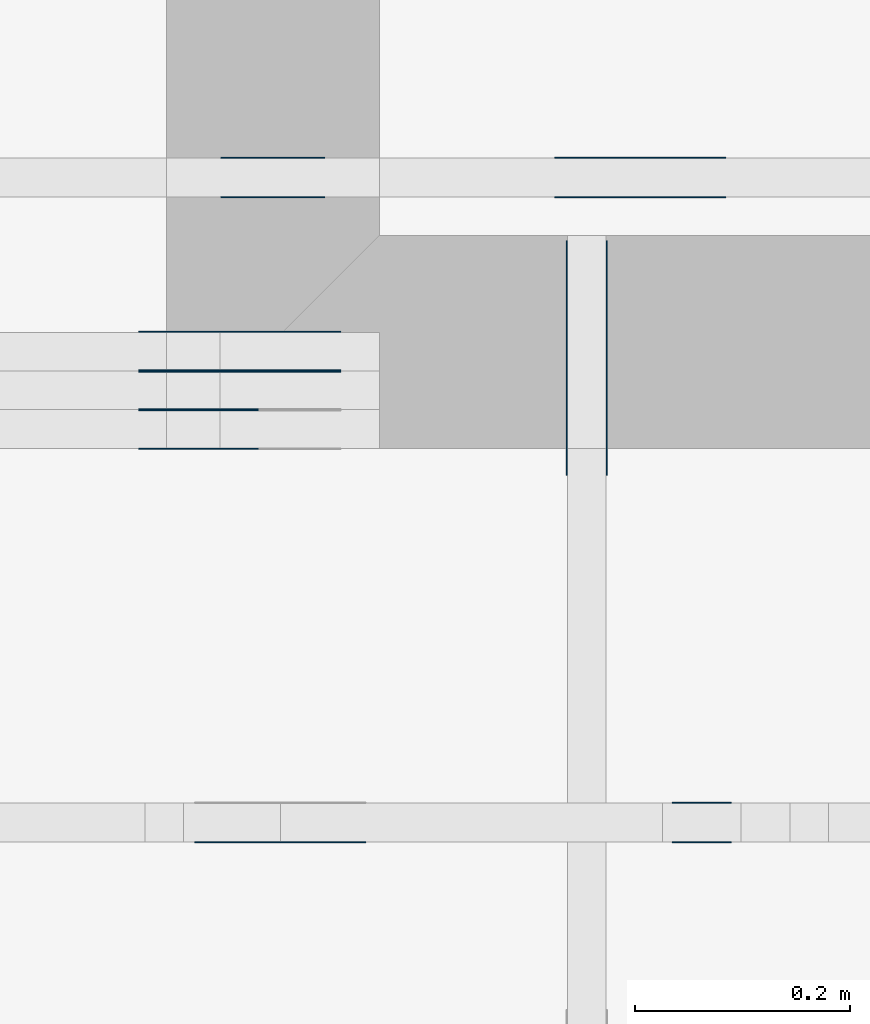
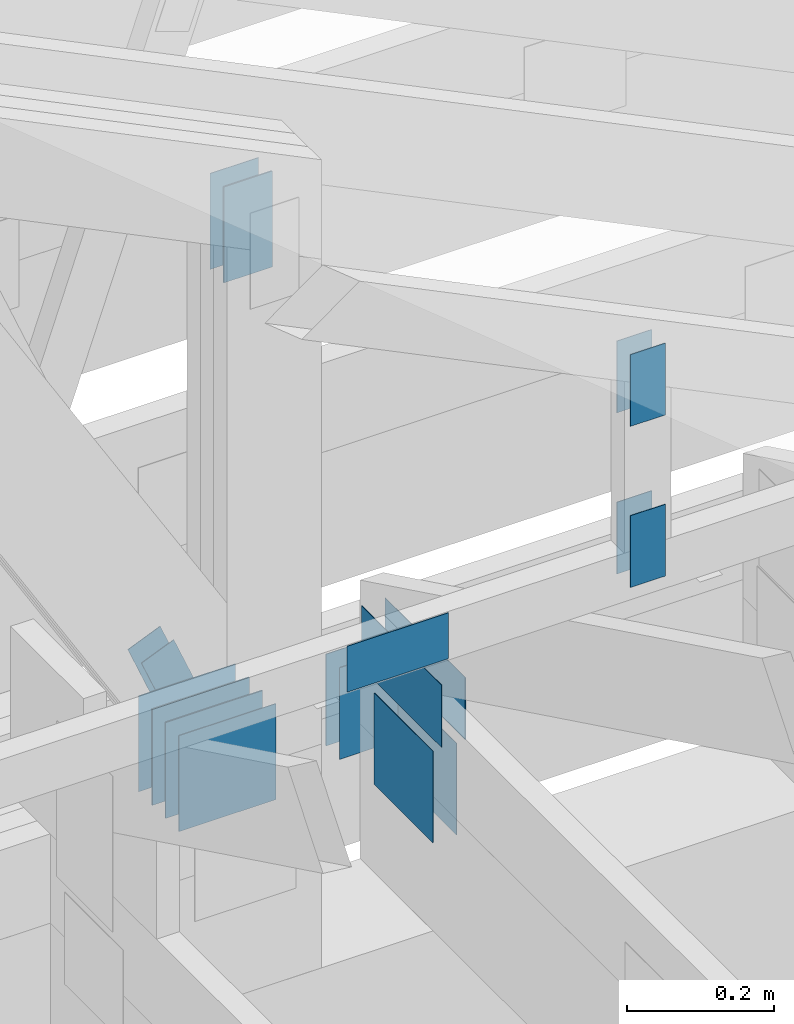
# One storey, part 129 of 159: 22 plates, 4 elements without a shape of their own.
"""IFC2X3 building model written with IfcOpenShell, lengths in millimetres."""

from ifc_helpers import new_model, si_unit, frame, origin, origin_with_axes, origin_2d, place, context, project, spatial, faceted_brep, element, aggregate, save


model = new_model("IFC2X3")

# Units and contexts
model_context = context("Model", 3, precision=1e-05, world=origin())
plan_context = context("Plan", 2, precision=1e-05, world=origin_2d())
ifc_project = project(units=[si_unit("LENGTHUNIT", "METRE", prefix="MILLI"), si_unit("AREAUNIT", "SQUARE_METRE"), si_unit("VOLUMEUNIT", "CUBIC_METRE"), si_unit("SOLIDANGLEUNIT", "STERADIAN"), si_unit("PLANEANGLEUNIT", "RADIAN"), si_unit("MASSUNIT", "GRAM"), si_unit("TIMEUNIT", "SECOND"), si_unit("THERMODYNAMICTEMPERATUREUNIT", "DEGREE_CELSIUS"), si_unit("LUMINOUSINTENSITYUNIT", "LUMEN")], contexts=[model_context, plan_context])

# Site, building, storey
site_placement = place(None, origin_with_axes())
site = spatial("IfcSite", under=ifc_project, at=site_placement, CompositionType="ELEMENT")
building_placement = place(site_placement, origin_with_axes())
building = spatial("IfcBuilding", under=site, at=building_placement, Name="Plan 1", CompositionType="ELEMENT")
storey_placement = place(building_placement, origin_with_axes())
storey = spatial("IfcBuildingStorey", under=building, at=storey_placement, Name="Etasje 1", CompositionType="ELEMENT", Elevation=0.0)

# Assembly, plates
assembly_1_placement = place(storey_placement, frame((10700.012663101485, 8801.999999990367, 0.0), z_axis=(0.0, -1.0, 6.123031769111886e-17), x_axis=(1.0, 0.0, 0.0)))
assembly_1 = element("IfcElementAssembly", 1, at=assembly_1_placement, inside=storey, Name="T8 (1)", AssemblyPlace="FACTORY", PredefinedType="TRUSS")
plate_1_placement = place(assembly_1_placement, frame((5888.0, 1290.2585957794156, -73.0), z_axis=(0.0, 0.0, 1.0), x_axis=(6.123031769111886e-17, -1.0, 0.0)))
plate_1 = element("IfcPlate", 2, at=plate_1_placement, Name="GNT100S 76x159", context=model_context, shape_type="Brep", body=[
    faceted_brep([(159.0000508575406, 76.0, 1.0), (5.085754060019099e-05, 76.0, 1.0), (5.085754060019099e-05, 0.0, 1.0), (159.0000508575406, 0.0, 1.0), (5.085754060019099e-05, 76.0, 6.22804673587734e-21), (159.0000508575406, 76.0, 1.9471247253822535e-14), (159.0000508575406, 0.0, 1.9471247253822535e-14), (5.085754060019099e-05, 0.0, 6.22804673587734e-21), (159.0, 3.4557877981217407e-10, 1.788345410772899e-30), (159.0, 3.4557884104249176e-10, 1.0), (1.1247455413666031e-32, 3.456080479040304e-10, 1.0), (0.0, 3.4560798667371273e-10, 0.0), (159.0, 76.00000000034561, 0.0), (159.0, 76.00000000034561, 1.0), (159.0, 3.4560798667371273e-10, 1.0), (159.0, 3.4560798667371273e-10, 0.0), (-2.4308653429145085e-63, 76.00000000034561, 0.0), (-3.7491518045553436e-33, 76.00000000034561, 1.0), (159.0, 76.0000000003456, 1.0), (159.0, 76.0000000003456, -7.888609052210118e-31), (4.232337364123881e-26, 3.4560798667371273e-10, -2.5914736138129785e-42), (6.123031773344224e-17, 3.4560798667371273e-10, 1.0), (9.36823860678351e-15, 76.00000000034561, 1.0), (9.307008289092391e-15, 76.00000000034561, -5.698710742950037e-31)], [[[0, 1, 2, 3]], [[4, 5, 6, 7]], [[8, 9, 10, 11]], [[12, 13, 14, 15]], [[16, 17, 18, 19]], [[20, 21, 22, 23]]]),
])
plate_2_placement = place(assembly_1_placement, frame((5888.0, 1290.2585957794156, -72.0), z_axis=(0.0, 0.0, 1.0), x_axis=(6.123031769111886e-17, -1.0, 0.0)))
plate_2 = element("IfcPlate", 3, at=plate_2_placement, Name="GNT100S 76x159", context=model_context, shape_type="Brep", body=[
    faceted_brep([(159.0000508575406, 76.0, 1.0), (5.085754060019099e-05, 76.0, 1.0), (5.085754060019099e-05, 0.0, 1.0), (159.0000508575406, 0.0, 1.0), (5.085754060019099e-05, 76.0, 6.22804673587734e-21), (159.0000508575406, 76.0, 1.9471247253822535e-14), (159.0000508575406, 0.0, 1.9471247253822535e-14), (5.085754060019099e-05, 0.0, 6.22804673587734e-21), (159.0, 3.4557877981217407e-10, 1.788345410772899e-30), (159.0, 3.4557884104249176e-10, 1.0), (1.1247455413666031e-32, 3.456080479040304e-10, 1.0), (0.0, 3.4560798667371273e-10, 0.0), (159.0, 76.00000000034561, 0.0), (159.0, 76.00000000034561, 1.0), (159.0, 3.4560798667371273e-10, 1.0), (159.0, 3.4560798667371273e-10, 0.0), (-2.4308653429145085e-63, 76.00000000034561, 0.0), (-3.7491518045553436e-33, 76.00000000034561, 1.0), (159.0, 76.0000000003456, 1.0), (159.0, 76.0000000003456, -7.888609052210118e-31), (4.232337364123881e-26, 3.4560798667371273e-10, -2.5914736138129785e-42), (6.123031773344224e-17, 3.4560798667371273e-10, 1.0), (9.36823860678351e-15, 76.00000000034561, 1.0), (9.307008289092391e-15, 76.00000000034561, -5.698710742950037e-31)], [[[0, 1, 2, 3]], [[4, 5, 6, 7]], [[8, 9, 10, 11]], [[12, 13, 14, 15]], [[16, 17, 18, 19]], [[20, 21, 22, 23]]]),
])
plate_3_placement = place(assembly_1_placement, frame((5888.0, 1290.2585957794156, -109.0), z_axis=(0.0, 0.0, 1.0), x_axis=(6.123031769111886e-17, -1.0, 0.0)))
plate_3 = element("IfcPlate", 4, at=plate_3_placement, Name="GNT100S 76x159", context=model_context, shape_type="Brep", body=[
    faceted_brep([(159.0000508575406, 76.0, 1.0), (5.085754060019099e-05, 76.0, 1.0), (5.085754060019099e-05, 0.0, 1.0), (159.0000508575406, 0.0, 1.0), (5.085754060019099e-05, 76.0, 6.22804673587734e-21), (159.0000508575406, 76.0, 1.9471247253822535e-14), (159.0000508575406, 0.0, 1.9471247253822535e-14), (5.085754060019099e-05, 0.0, 6.22804673587734e-21), (159.0, 3.4557877981217407e-10, 1.788345410772899e-30), (159.0, 3.4557884104249176e-10, 1.0), (1.1247455413666031e-32, 3.456080479040304e-10, 1.0), (0.0, 3.4560798667371273e-10, 0.0), (159.0, 76.00000000034561, 0.0), (159.0, 76.00000000034561, 1.0), (159.0, 3.4560798667371273e-10, 1.0), (159.0, 3.4560798667371273e-10, 0.0), (-2.4308653429145085e-63, 76.00000000034561, 0.0), (-3.7491518045553436e-33, 76.00000000034561, 1.0), (159.0, 76.0000000003456, 1.0), (159.0, 76.0000000003456, -7.888609052210118e-31), (4.232337364123881e-26, 3.4560798667371273e-10, -2.5914736138129785e-42), (6.123031773344224e-17, 3.4560798667371273e-10, 1.0), (9.36823860678351e-15, 76.00000000034561, 1.0), (9.307008289092391e-15, 76.00000000034561, -5.698710742950037e-31)], [[[0, 1, 2, 3]], [[4, 5, 6, 7]], [[8, 9, 10, 11]], [[12, 13, 14, 15]], [[16, 17, 18, 19]], [[20, 21, 22, 23]]]),
])
plate_4_placement = place(assembly_1_placement, frame((5928.0, 304.75, 0.0), z_axis=(0.0, 0.0, 1.0), x_axis=(6.123031769111886e-17, 1.0, 0.0)))
plate_4 = element("IfcPlate", 5, at=plate_4_placement, Name="GNT100S 152x159", context=model_context, shape_type="Brep", body=[
    faceted_brep([(159.0, 152.0, 1.0), (0.0, 152.0, 1.0), (0.0, 0.0, 1.0), (159.0, 0.0, 1.0), (0.0, 152.0, 0.0), (159.0, 152.0, 1.9471241025775798e-14), (159.0, 0.0, 1.9471241025775798e-14), (0.0, 0.0, 0.0), (159.0, -2.92068615386637e-14, 1.788345410772899e-30), (159.0, -2.914563122097258e-14, 1.0), (1.1247455413666031e-32, 6.123031769111886e-17, 1.0), (0.0, 0.0, 0.0), (159.0, 152.0, 0.0), (159.0, 152.0, 1.0), (159.0, 0.0, 1.0), (159.0, 0.0, 0.0), (0.0, 152.0, 0.0), (-3.7491518045553436e-33, 152.0, 1.0), (159.0, 152.0, 1.0), (159.0, 152.0, 0.0), (0.0, 0.0, 0.0), (6.123031769111886e-17, -7.498303609110687e-33, 1.0), (1.8675246895791253e-14, 152.0, 1.0), (1.8614016578100134e-14, 152.0, -1.1397421485848245e-30)], [[[0, 1, 2, 3]], [[4, 5, 6, 7]], [[8, 9, 10, 11]], [[12, 13, 14, 15]], [[16, 17, 18, 19]], [[20, 21, 22, 23]]]),
])
plate_5_placement = place(assembly_1_placement, frame((5928.0, 304.75, -37.0), z_axis=(0.0, 0.0, 1.0), x_axis=(6.123031769111886e-17, 1.0, 0.0)))
plate_5 = element("IfcPlate", 6, at=plate_5_placement, Name="GNT100S 152x159", context=model_context, shape_type="Brep", body=[
    faceted_brep([(159.0, 152.0, 1.0), (0.0, 152.0, 1.0), (0.0, 0.0, 1.0), (159.0, 0.0, 1.0), (0.0, 152.0, 0.0), (159.0, 152.0, 1.9471241025775798e-14), (159.0, 0.0, 1.9471241025775798e-14), (0.0, 0.0, 0.0), (159.0, -2.92068615386637e-14, 1.788345410772899e-30), (159.0, -2.914563122097258e-14, 1.0), (1.1247455413666031e-32, 6.123031769111886e-17, 1.0), (0.0, 0.0, 0.0), (159.0, 152.0, 0.0), (159.0, 152.0, 1.0), (159.0, 0.0, 1.0), (159.0, 0.0, 0.0), (0.0, 152.0, 0.0), (-3.7491518045553436e-33, 152.0, 1.0), (159.0, 152.0, 1.0), (159.0, 152.0, 0.0), (0.0, 0.0, 0.0), (6.123031769111886e-17, -7.498303609110687e-33, 1.0), (1.8675246895791253e-14, 152.0, 1.0), (1.8614016578100134e-14, 152.0, -1.1397421485848245e-30)], [[[0, 1, 2, 3]], [[4, 5, 6, 7]], [[8, 9, 10, 11]], [[12, 13, 14, 15]], [[16, 17, 18, 19]], [[20, 21, 22, 23]]]),
])
plate_6_placement = place(assembly_1_placement, frame((5928.0, 304.75, -36.0), z_axis=(0.0, 0.0, 1.0), x_axis=(6.123031769111886e-17, 1.0, 0.0)))
plate_6 = element("IfcPlate", 7, at=plate_6_placement, Name="GNT100S 152x159", context=model_context, shape_type="Brep", body=[
    faceted_brep([(159.0, 152.0, 1.0), (0.0, 152.0, 1.0), (0.0, 0.0, 1.0), (159.0, 0.0, 1.0), (0.0, 152.0, 0.0), (159.0, 152.0, 1.9471241025775798e-14), (159.0, 0.0, 1.9471241025775798e-14), (0.0, 0.0, 0.0), (159.0, -2.92068615386637e-14, 1.788345410772899e-30), (159.0, -2.914563122097258e-14, 1.0), (1.1247455413666031e-32, 6.123031769111886e-17, 1.0), (0.0, 0.0, 0.0), (159.0, 152.0, 0.0), (159.0, 152.0, 1.0), (159.0, 0.0, 1.0), (159.0, 0.0, 0.0), (0.0, 152.0, 0.0), (-3.7491518045553436e-33, 152.0, 1.0), (159.0, 152.0, 1.0), (159.0, 152.0, 0.0), (0.0, 0.0, 0.0), (6.123031769111886e-17, -7.498303609110687e-33, 1.0), (1.8675246895791253e-14, 152.0, 1.0), (1.8614016578100134e-14, 152.0, -1.1397421485848245e-30)], [[[0, 1, 2, 3]], [[4, 5, 6, 7]], [[8, 9, 10, 11]], [[12, 13, 14, 15]], [[16, 17, 18, 19]], [[20, 21, 22, 23]]]),
])
plate_7_placement = place(assembly_1_placement, frame((5928.0, 304.75, -73.0), z_axis=(0.0, 0.0, 1.0), x_axis=(6.123031769111886e-17, 1.0, 0.0)))
plate_7 = element("IfcPlate", 8, at=plate_7_placement, Name="GNT100S 152x159", context=model_context, shape_type="Brep", body=[
    faceted_brep([(159.0, 152.0, 1.0), (0.0, 152.0, 1.0), (0.0, 0.0, 1.0), (159.0, 0.0, 1.0), (0.0, 152.0, 0.0), (159.0, 152.0, 1.9471241025775798e-14), (159.0, 0.0, 1.9471241025775798e-14), (0.0, 0.0, 0.0), (159.0, -2.92068615386637e-14, 1.788345410772899e-30), (159.0, -2.914563122097258e-14, 1.0), (1.1247455413666031e-32, 6.123031769111886e-17, 1.0), (0.0, 0.0, 0.0), (159.0, 152.0, 0.0), (159.0, 152.0, 1.0), (159.0, 0.0, 1.0), (159.0, 0.0, 0.0), (0.0, 152.0, 0.0), (-3.7491518045553436e-33, 152.0, 1.0), (159.0, 152.0, 1.0), (159.0, 152.0, 0.0), (0.0, 0.0, 0.0), (6.123031769111886e-17, -7.498303609110687e-33, 1.0), (1.8675246895791253e-14, 152.0, 1.0), (1.8614016578100134e-14, 152.0, -1.1397421485848245e-30)], [[[0, 1, 2, 3]], [[4, 5, 6, 7]], [[8, 9, 10, 11]], [[12, 13, 14, 15]], [[16, 17, 18, 19]], [[20, 21, 22, 23]]]),
])
plate_8_placement = place(assembly_1_placement, frame((5928.0, 304.75, -72.0), z_axis=(0.0, 0.0, 1.0), x_axis=(6.123031769111886e-17, 1.0, 0.0)))
plate_8 = element("IfcPlate", 9, at=plate_8_placement, Name="GNT100S 152x159", context=model_context, shape_type="Brep", body=[
    faceted_brep([(159.0, 152.0, 1.0), (0.0, 152.0, 1.0), (0.0, 0.0, 1.0), (159.0, 0.0, 1.0), (0.0, 152.0, 0.0), (159.0, 152.0, 1.9471241025775798e-14), (159.0, 0.0, 1.9471241025775798e-14), (0.0, 0.0, 0.0), (159.0, -2.92068615386637e-14, 1.788345410772899e-30), (159.0, -2.914563122097258e-14, 1.0), (1.1247455413666031e-32, 6.123031769111886e-17, 1.0), (0.0, 0.0, 0.0), (159.0, 152.0, 0.0), (159.0, 152.0, 1.0), (159.0, 0.0, 1.0), (159.0, 0.0, 0.0), (0.0, 152.0, 0.0), (-3.7491518045553436e-33, 152.0, 1.0), (159.0, 152.0, 1.0), (159.0, 152.0, 0.0), (0.0, 0.0, 0.0), (6.123031769111886e-17, -7.498303609110687e-33, 1.0), (1.8675246895791253e-14, 152.0, 1.0), (1.8614016578100134e-14, 152.0, -1.1397421485848245e-30)], [[[0, 1, 2, 3]], [[4, 5, 6, 7]], [[8, 9, 10, 11]], [[12, 13, 14, 15]], [[16, 17, 18, 19]], [[20, 21, 22, 23]]]),
])
plate_9_placement = place(assembly_1_placement, frame((5928.0, 304.75, -109.0), z_axis=(0.0, 0.0, 1.0), x_axis=(6.123031769111886e-17, 1.0, 0.0)))
plate_9 = element("IfcPlate", 10, at=plate_9_placement, Name="GNT100S 152x159", context=model_context, shape_type="Brep", body=[
    faceted_brep([(159.0, 152.0, 1.0), (0.0, 152.0, 1.0), (0.0, 0.0, 1.0), (159.0, 0.0, 1.0), (0.0, 152.0, 0.0), (159.0, 152.0, 1.9471241025775798e-14), (159.0, 0.0, 1.9471241025775798e-14), (0.0, 0.0, 0.0), (159.0, -2.92068615386637e-14, 1.788345410772899e-30), (159.0, -2.914563122097258e-14, 1.0), (1.1247455413666031e-32, 6.123031769111886e-17, 1.0), (0.0, 0.0, 0.0), (159.0, 152.0, 0.0), (159.0, 152.0, 1.0), (159.0, 0.0, 1.0), (159.0, 0.0, 0.0), (0.0, 152.0, 0.0), (-3.7491518045553436e-33, 152.0, 1.0), (159.0, 152.0, 1.0), (159.0, 152.0, 0.0), (0.0, 0.0, 0.0), (6.123031769111886e-17, -7.498303609110687e-33, 1.0), (1.8675246895791253e-14, 152.0, 1.0), (1.8614016578100134e-14, 152.0, -1.1397421485848245e-30)], [[[0, 1, 2, 3]], [[4, 5, 6, 7]], [[8, 9, 10, 11]], [[12, 13, 14, 15]], [[16, 17, 18, 19]], [[20, 21, 22, 23]]]),
])
aggregate(assembly_1, [plate_1, plate_2, plate_3, plate_4, plate_5, plate_6, plate_7, plate_8, plate_9])

assembly_2_placement = place(storey_placement, frame((10000.012663278096, 9072.000080051337, 1.1021457184401395e-15), z_axis=(9.811600543477555e-09, 1.0, 6.123031769111886e-17), x_axis=(-1.0, 9.811600543477555e-09, 0.0)))
assembly_2 = element("IfcElementAssembly", 11, at=assembly_2_placement, inside=storey, Name="T9 (79)", AssemblyPlace="FACTORY", PredefinedType="TRUSS")
plate_10_placement = place(assembly_2_placement, frame((-7022.14892578125, 147.0, 0.0), z_axis=(0.0, 0.0, 1.0), x_axis=(1.0, 0.0, 0.0)))
plate_10 = element("IfcPlate", 12, at=plate_10_placement, Name="GNT100S 152x159", context=model_context, shape_type="Brep", body=[
    faceted_brep([(159.0, 152.0, 1.0), (0.0, 152.0, 1.0), (0.0, 0.0, 1.0), (159.0, 0.0, 1.0), (0.0, 152.0, 0.0), (159.0, 152.0, 1.9471241025775798e-14), (159.0, 0.0, 1.9471241025775798e-14), (0.0, 0.0, 0.0), (159.00020807865712, -2.920689976083054e-14, 1.7883477511283173e-30), (159.00020807865712, -2.914566944313942e-14, 1.0), (0.00020807865712413331, 6.119209552427751e-17, 1.0), (0.00020807865712413331, -3.822216684135623e-20, 2.340355418539191e-36), (159.00020807865712, 152.0, 0.0), (159.00020807865712, 152.0, 1.0), (159.00020807865712, 0.0, 1.0), (159.00020807865712, 0.0, 0.0), (0.00020807865712413331, 152.0, 0.0), (0.00020807865712413331, 152.0, 1.0), (159.00020807865712, 152.0, 1.0), (159.00020807865712, 152.0, 0.0), (0.00020807865712413331, 0.0, 0.0), (0.00020807865712419455, -7.498303609110687e-33, 1.0), (0.00020807865714280856, 152.0, 1.0), (0.00020807865714274733, 152.0, -1.1397427715968304e-30)], [[[0, 1, 2, 3]], [[4, 5, 6, 7]], [[8, 9, 10, 11]], [[12, 13, 14, 15]], [[16, 17, 18, 19]], [[20, 21, 22, 23]]]),
])
plate_11_placement = place(assembly_2_placement, frame((-7022.14892578125, 147.0, -37.0), z_axis=(0.0, 0.0, 1.0), x_axis=(1.0, 0.0, 0.0)))
plate_11 = element("IfcPlate", 13, at=plate_11_placement, Name="GNT100S 152x159", context=model_context, shape_type="Brep", body=[
    faceted_brep([(159.0, 152.0, 1.0), (0.0, 152.0, 1.0), (0.0, 0.0, 1.0), (159.0, 0.0, 1.0), (0.0, 152.0, 0.0), (159.0, 152.0, 1.9471241025775798e-14), (159.0, 0.0, 1.9471241025775798e-14), (0.0, 0.0, 0.0), (159.00020807865712, -2.920689976083054e-14, 1.7883477511283173e-30), (159.00020807865712, -2.914566944313942e-14, 1.0), (0.00020807865712413331, 6.119209552427751e-17, 1.0), (0.00020807865712413331, -3.822216684135623e-20, 2.340355418539191e-36), (159.00020807865712, 152.0, 0.0), (159.00020807865712, 152.0, 1.0), (159.00020807865712, 0.0, 1.0), (159.00020807865712, 0.0, 0.0), (0.00020807865712413331, 152.0, 0.0), (0.00020807865712413331, 152.0, 1.0), (159.00020807865712, 152.0, 1.0), (159.00020807865712, 152.0, 0.0), (0.00020807865712413331, 0.0, 0.0), (0.00020807865712419455, -7.498303609110687e-33, 1.0), (0.00020807865714280856, 152.0, 1.0), (0.00020807865714274733, 152.0, -1.1397427715968304e-30)], [[[0, 1, 2, 3]], [[4, 5, 6, 7]], [[8, 9, 10, 11]], [[12, 13, 14, 15]], [[16, 17, 18, 19]], [[20, 21, 22, 23]]]),
])
plate_12_placement = place(assembly_2_placement, frame((-6598.611314110998, 305.4957525768082, 0.0), z_axis=(0.0, 0.0, 1.0), x_axis=(0.3861849324176126, 0.9224213776651125, 0.0)))
plate_12 = element("IfcPlate", 14, at=plate_12_placement, Name="GNT100S 55x119", context=model_context, shape_type="Brep", body=[
    faceted_brep([(119.00000321189373, 55.00025658546747, 1.0), (0.0, 55.00025658546747, 1.0), (8.409291740463232e-05, 5.03993305756012e-05, 1.0), (119.00008730481068, 5.03993305756012e-05, 1.0), (0.0, 55.00025658546747, 0.0), (119.00000321189373, 55.00025658546747, 1.4572816003816836e-14), (119.00008730481068, 0.0, 1.4572826301888877e-14), (8.409291740463232e-05, 0.0, 1.0298072096517311e-20), (119.00004365240966, 0.00012829272412097185, 3.894471088794039e-30), (119.00004365240966, 0.00012829272412103308, 1.0), (4.36524101132818e-05, 0.0001282927250941314, 1.0), (4.36524101132818e-05, 0.00012829272509407017, 3.009265538105056e-36), (119.00004365240966, 55.000128292724185, 0.0), (119.00004365240966, 55.000128292724185, 1.0), (119.00004365240966, 0.0001282927241845755, 1.0), (119.00004365240966, 0.0001282927241845755, 0.0), (4.365240965853445e-05, 55.000128292724185, 0.0), (4.365240965853445e-05, 55.000128292724185, 1.0), (119.00004365240966, 55.00012829272418, 1.0), (119.00004365240966, 55.00012829272418, -3.944304526105059e-31), (4.365241011328186e-05, 0.00012829272509407017, -3.385423730368188e-36), (4.365241011334309e-05, 0.00012829272509407017, 1.0), (4.3652409680430105e-05, 55.000128292724185, 1.0), (4.3652409680368875e-05, 55.000128292724185, -1.3369286575630868e-30)], [[[0, 1, 2, 3]], [[4, 5, 6, 7]], [[8, 9, 10, 11]], [[12, 13, 14, 15]], [[16, 17, 18, 19]], [[20, 21, 22, 23]]]),
])
plate_13_placement = place(assembly_2_placement, frame((-6598.611314110998, 305.4957525768082, -37.0), z_axis=(0.0, 0.0, 1.0), x_axis=(0.3861849324176126, 0.9224213776651125, 0.0)))
plate_13 = element("IfcPlate", 15, at=plate_13_placement, Name="GNT100S 55x119", context=model_context, shape_type="Brep", body=[
    faceted_brep([(119.00000321189373, 55.00025658546747, 1.0), (0.0, 55.00025658546747, 1.0), (8.409291740463232e-05, 5.03993305756012e-05, 1.0), (119.00008730481068, 5.03993305756012e-05, 1.0), (0.0, 55.00025658546747, 0.0), (119.00000321189373, 55.00025658546747, 1.4572816003816836e-14), (119.00008730481068, 0.0, 1.4572826301888877e-14), (8.409291740463232e-05, 0.0, 1.0298072096517311e-20), (119.00004365240966, 0.00012829272412097185, 3.894471088794039e-30), (119.00004365240966, 0.00012829272412103308, 1.0), (4.36524101132818e-05, 0.0001282927250941314, 1.0), (4.36524101132818e-05, 0.00012829272509407017, 3.009265538105056e-36), (119.00004365240966, 55.000128292724185, 0.0), (119.00004365240966, 55.000128292724185, 1.0), (119.00004365240966, 0.0001282927241845755, 1.0), (119.00004365240966, 0.0001282927241845755, 0.0), (4.365240965853445e-05, 55.000128292724185, 0.0), (4.365240965853445e-05, 55.000128292724185, 1.0), (119.00004365240966, 55.00012829272418, 1.0), (119.00004365240966, 55.00012829272418, -3.944304526105059e-31), (4.365241011328186e-05, 0.00012829272509407017, -3.385423730368188e-36), (4.365241011334309e-05, 0.00012829272509407017, 1.0), (4.3652409680430105e-05, 55.000128292724185, 1.0), (4.3652409680368875e-05, 55.000128292724185, -1.3369286575630868e-30)], [[[0, 1, 2, 3]], [[4, 5, 6, 7]], [[8, 9, 10, 11]], [[12, 13, 14, 15]], [[16, 17, 18, 19]], [[20, 21, 22, 23]]]),
])
aggregate(assembly_2, [plate_10, plate_11, plate_12, plate_13])

assembly_3_placement = place(storey_placement, frame((16875.02226140475, -699.9989301294827, 1.1021457184401395e-15), z_axis=(-1.0, 1.836909530733566e-16, 6.123031769111886e-17), x_axis=(-1.836909530733566e-16, -1.0, 0.0)))
assembly_3 = element("IfcElementAssembly", 16, at=assembly_3_placement, inside=storey, Name="V7 (32)", AssemblyPlace="FACTORY", PredefinedType="TRUSS")
plate_14_placement = place(assembly_3_placement, frame((-9694.9990234375, 319.5, 0.0), z_axis=(0.0, 0.0, 1.0), x_axis=(1.0, 0.0, 0.0)))
plate_14 = element("IfcPlate", 17, at=plate_14_placement, Name="GNT100S 103x218", context=model_context, shape_type="Brep", body=[
    faceted_brep([(218.0, 103.0, 1.0), (0.0, 103.0, 1.0), (0.0, 0.0, 1.0), (218.0, 0.0, 1.0), (0.0, 103.0, 0.0), (218.0, 103.0, 2.6696418513327824e-14), (218.0, 0.0, 2.6696418513327824e-14), (0.0, 0.0, 0.0), (218.00009946359205, -4.004464604055376e-14, 2.4519463988915115e-30), (218.00009946359205, -3.998341572286264e-14, 1.0), (9.946359205059707e-05, 6.121204712909899e-17, 1.0), (9.946359205059707e-05, -1.827056201987371e-20, 1.1187123168721576e-36), (218.00009946359205, 103.0, 0.0), (218.00009946359205, 103.0, 1.0), (218.00009946359205, 0.0, 1.0), (218.00009946359205, 0.0, 0.0), (9.946359205059707e-05, 103.0, 0.0), (9.946359205059707e-05, 103.0, 1.0), (218.00009946359205, 102.99999999999999, 1.0), (218.00009946359205, 102.99999999999999, -7.888609052210118e-31), (9.946359205059707e-05, 0.0, 0.0), (9.94635920506583e-05, -7.498303609110687e-33, 1.0), (9.946359206327175e-05, 103.0, 1.0), (9.946359206321052e-05, 103.0, -7.723249910891245e-31)], [[[0, 1, 2, 3]], [[4, 5, 6, 7]], [[8, 9, 10, 11]], [[12, 13, 14, 15]], [[16, 17, 18, 19]], [[20, 21, 22, 23]]]),
])
plate_15_placement = place(assembly_3_placement, frame((-9694.9990234375, 319.5, -37.0), z_axis=(0.0, 0.0, 1.0), x_axis=(1.0, 0.0, 0.0)))
plate_15 = element("IfcPlate", 18, at=plate_15_placement, Name="GNT100S 103x218", context=model_context, shape_type="Brep", body=[
    faceted_brep([(218.0, 103.0, 1.0), (0.0, 103.0, 1.0), (0.0, 0.0, 1.0), (218.0, 0.0, 1.0), (0.0, 103.0, 0.0), (218.0, 103.0, 2.6696418513327824e-14), (218.0, 0.0, 2.6696418513327824e-14), (0.0, 0.0, 0.0), (218.00009946359205, -4.004464604055376e-14, 2.4519463988915115e-30), (218.00009946359205, -3.998341572286264e-14, 1.0), (9.946359205059707e-05, 6.121204712909899e-17, 1.0), (9.946359205059707e-05, -1.827056201987371e-20, 1.1187123168721576e-36), (218.00009946359205, 103.0, 0.0), (218.00009946359205, 103.0, 1.0), (218.00009946359205, 0.0, 1.0), (218.00009946359205, 0.0, 0.0), (9.946359205059707e-05, 103.0, 0.0), (9.946359205059707e-05, 103.0, 1.0), (218.00009946359205, 102.99999999999999, 1.0), (218.00009946359205, 102.99999999999999, -7.888609052210118e-31), (9.946359205059707e-05, 0.0, 0.0), (9.94635920506583e-05, -7.498303609110687e-33, 1.0), (9.946359206327175e-05, 103.0, 1.0), (9.946359206321052e-05, 103.0, -7.723249910891245e-31)], [[[0, 1, 2, 3]], [[4, 5, 6, 7]], [[8, 9, 10, 11]], [[12, 13, 14, 15]], [[16, 17, 18, 19]], [[20, 21, 22, 23]]]),
])
plate_16_placement = place(assembly_3_placement, frame((-9659.9990234375, 147.0, 0.0), z_axis=(0.0, 0.0, 1.0), x_axis=(1.0, 0.0, 0.0)))
plate_16 = element("IfcPlate", 19, at=plate_16_placement, Name="GNT100S 152x159", context=model_context, shape_type="Brep", body=[
    faceted_brep([(159.0, 152.0, 1.0), (0.0, 152.0, 1.0), (0.0, 0.0, 1.0), (159.0, 0.0, 1.0), (0.0, 152.0, 0.0), (159.0, 152.0, 1.9471241025775798e-14), (159.0, 0.0, 1.9471241025775798e-14), (0.0, 0.0, 0.0), (159.00009946362115, 1.69745086203597e-13, 1.788346529485543e-30), (159.00009946362115, 1.6980631652128811e-13, 1.0), (9.946362115442753e-05, 1.990131780599518e-13, 1.0), (9.946362115442753e-05, 1.989519477422607e-13, 1.1187126440350437e-36), (159.00009946362115, 152.00000000000023, 0.0), (159.00009946362115, 152.00000000000023, 1.0), (159.00009946362115, 1.9895196601282805e-13, 1.0), (159.00009946362115, 1.9895196601282805e-13, 0.0), (9.946362115442753e-05, 152.00000000000023, 0.0), (9.946362115442753e-05, 152.00000000000023, 1.0), (159.00009946362115, 152.00000000000023, 1.0), (159.00009946362115, 152.00000000000023, 0.0), (9.946362115442753e-05, 1.9895196601282805e-13, 0.0), (9.946362115448876e-05, 1.9895196601282805e-13, 1.0), (9.946362117310278e-05, 152.00000000000023, 1.0), (9.946362117304154e-05, 152.00000000000023, -1.1397420192804459e-30)], [[[0, 1, 2, 3]], [[4, 5, 6, 7]], [[8, 9, 10, 11]], [[12, 13, 14, 15]], [[16, 17, 18, 19]], [[20, 21, 22, 23]]]),
])
plate_17_placement = place(assembly_3_placement, frame((-9659.9990234375, 147.0, -37.0), z_axis=(0.0, 0.0, 1.0), x_axis=(1.0, 0.0, 0.0)))
plate_17 = element("IfcPlate", 20, at=plate_17_placement, Name="GNT100S 152x159", context=model_context, shape_type="Brep", body=[
    faceted_brep([(159.0, 152.0, 1.0), (0.0, 152.0, 1.0), (0.0, 0.0, 1.0), (159.0, 0.0, 1.0), (0.0, 152.0, 0.0), (159.0, 152.0, 1.9471241025775798e-14), (159.0, 0.0, 1.9471241025775798e-14), (0.0, 0.0, 0.0), (159.00009946362115, 1.69745086203597e-13, 1.788346529485543e-30), (159.00009946362115, 1.6980631652128811e-13, 1.0), (9.946362115442753e-05, 1.990131780599518e-13, 1.0), (9.946362115442753e-05, 1.989519477422607e-13, 1.1187126440350437e-36), (159.00009946362115, 152.00000000000023, 0.0), (159.00009946362115, 152.00000000000023, 1.0), (159.00009946362115, 1.9895196601282805e-13, 1.0), (159.00009946362115, 1.9895196601282805e-13, 0.0), (9.946362115442753e-05, 152.00000000000023, 0.0), (9.946362115442753e-05, 152.00000000000023, 1.0), (159.00009946362115, 152.00000000000023, 1.0), (159.00009946362115, 152.00000000000023, 0.0), (9.946362115442753e-05, 1.9895196601282805e-13, 0.0), (9.946362115448876e-05, 1.9895196601282805e-13, 1.0), (9.946362117310278e-05, 152.00000000000023, 1.0), (9.946362117304154e-05, 152.00000000000023, -1.1397420192804459e-30)], [[[0, 1, 2, 3]], [[4, 5, 6, 7]], [[8, 9, 10, 11]], [[12, 13, 14, 15]], [[16, 17, 18, 19]], [[20, 21, 22, 23]]]),
])
aggregate(assembly_3, [plate_14, plate_15, plate_16, plate_17])

assembly_4_placement = place(storey_placement, frame((11246.01259527543, 8436.00006782605, 727.7147722720857), z_axis=(0.0, -1.0, 6.123031769111886e-17), x_axis=(1.0, 0.0, 0.0)))
assembly_4 = element("IfcElementAssembly", 21, at=assembly_4_placement, inside=storey, Name="Tr1 (1)", AssemblyPlace="FACTORY", PredefinedType="TRUSS")
plate_18_placement = place(assembly_4_placement, frame((5726.5, 415.7619324063278, 0.0), z_axis=(0.0, 0.0, 1.0), x_axis=(6.123031769111886e-17, -1.0, 0.0)))
plate_18 = element("IfcPlate", 22, at=plate_18_placement, Name="GNT100S 55x119", context=model_context, shape_type="Brep", body=[
    faceted_brep([(119.00000003328091, 55.0, 1.0), (3.328091224830132e-08, 55.0, 1.0), (3.328091224830132e-08, 0.0, 1.0), (119.00000003328091, 0.0, 1.0), (3.328091224830132e-08, 55.0, 4.0756016600274775e-24), (119.00000003328091, 55.0, 1.4572815614561892e-14), (119.00000003328091, 0.0, 1.4572815614561892e-14), (3.328091224830132e-08, 0.0, 4.0756016600274775e-24), (119.0, 6.782605485201705e-05, 1.3384468320270608e-30), (119.0, 6.782605485207828e-05, 1.0), (1.1247455413666031e-32, 6.78260548739375e-05, 1.0), (0.0, 6.782605487387627e-05, 0.0), (119.0, 55.000067826054874, 0.0), (119.0, 55.000067826054874, 1.0), (119.0, 6.782605487387627e-05, 1.0), (119.0, 6.782605487387627e-05, 0.0), (0.0, 55.000067826054874, 0.0), (-3.7491518045553436e-33, 55.000067826054874, 1.0), (119.0, 55.00006782605487, 1.0), (119.0, 55.00006782605487, -3.944304526105059e-31), (8.30602177532541e-21, 6.782605487387627e-05, -5.08580352052526e-37), (6.123862371289419e-17, 6.782605487387627e-05, 1.0), (6.796573569735969e-15, 55.000067826054874, 1.0), (6.73534325204485e-15, 55.000067826054874, -4.124072070814398e-31)], [[[0, 1, 2, 3]], [[4, 5, 6, 7]], [[8, 9, 10, 11]], [[12, 13, 14, 15]], [[16, 17, 18, 19]], [[20, 21, 22, 23]]]),
])
plate_19_placement = place(assembly_4_placement, frame((5726.5, 415.7619324063278, -37.0), z_axis=(0.0, 0.0, 1.0), x_axis=(6.123031769111886e-17, -1.0, 0.0)))
plate_19 = element("IfcPlate", 23, at=plate_19_placement, Name="GNT100S 55x119", context=model_context, shape_type="Brep", body=[
    faceted_brep([(119.00000003328091, 55.0, 1.0), (3.328091224830132e-08, 55.0, 1.0), (3.328091224830132e-08, 0.0, 1.0), (119.00000003328091, 0.0, 1.0), (3.328091224830132e-08, 55.0, 4.0756016600274775e-24), (119.00000003328091, 55.0, 1.4572815614561892e-14), (119.00000003328091, 0.0, 1.4572815614561892e-14), (3.328091224830132e-08, 0.0, 4.0756016600274775e-24), (119.0, 6.782605485201705e-05, 1.3384468320270608e-30), (119.0, 6.782605485207828e-05, 1.0), (1.1247455413666031e-32, 6.78260548739375e-05, 1.0), (0.0, 6.782605487387627e-05, 0.0), (119.0, 55.000067826054874, 0.0), (119.0, 55.000067826054874, 1.0), (119.0, 6.782605487387627e-05, 1.0), (119.0, 6.782605487387627e-05, 0.0), (0.0, 55.000067826054874, 0.0), (-3.7491518045553436e-33, 55.000067826054874, 1.0), (119.0, 55.00006782605487, 1.0), (119.0, 55.00006782605487, -3.944304526105059e-31), (8.30602177532541e-21, 6.782605487387627e-05, -5.08580352052526e-37), (6.123862371289419e-17, 6.782605487387627e-05, 1.0), (6.796573569735969e-15, 55.000067826054874, 1.0), (6.73534325204485e-15, 55.000067826054874, -4.124072070814398e-31)], [[[0, 1, 2, 3]], [[4, 5, 6, 7]], [[8, 9, 10, 11]], [[12, 13, 14, 15]], [[16, 17, 18, 19]], [[20, 21, 22, 23]]]),
])
plate_20_placement = place(assembly_4_placement, frame((5781.500067826054, 29.720829010009762, 0.0), z_axis=(0.0, 0.0, 1.0), x_axis=(6.123031769111886e-17, 1.0, 0.0)))
plate_20 = element("IfcPlate", 24, at=plate_20_placement, Name="GNT100S 55x119", context=model_context, shape_type="Brep", body=[
    faceted_brep([(118.99999618530272, 55.000067826053964, 1.0), (0.0, 55.000067826053964, 1.0), (3.552713678800501e-15, 6.782605396438157e-05, 1.0), (118.99999618530272, 6.782605396438157e-05, 1.0), (0.0, 55.000067826053964, 0.0), (118.99999618530272, 55.000067826053964, 1.4572815143336035e-14), (118.99999618530272, 6.782605396438157e-05, 1.4572815143336035e-14), (3.552713678800501e-15, 6.782605396438157e-05, 4.350675744370766e-31), (119.00000002049917, -2.1859223419494948e-14, 1.3384471944568212e-30), (119.00000002049917, -2.179799310180383e-14, 1.0), (2.0499189901102e-08, 6.123031392560313e-17, 1.0), (2.0499189901102e-08, -3.765515730165153e-24, 2.305637244289177e-40), (119.00000002049917, 55.0, 0.0), (119.00000002049917, 55.0, 1.0), (119.00000002049917, 0.0, 1.0), (119.00000002049917, 0.0, 0.0), (2.0499189901102e-08, 55.0, 0.0), (2.0499189901102e-08, 55.0, 1.0), (119.00000002049917, 54.99999999999999, 1.0), (119.00000002049917, 54.99999999999999, -3.944304526105059e-31), (2.0499189901102e-08, 0.0, 0.0), (2.0499189962332317e-08, -7.498303609110687e-33, 1.0), (2.0499196697667263e-08, 55.0, 1.0), (2.0499196636436946e-08, 55.0, -4.124066985010878e-31)], [[[0, 1, 2, 3]], [[4, 5, 6, 7]], [[8, 9, 10, 11]], [[12, 13, 14, 15]], [[16, 17, 18, 19]], [[20, 21, 22, 23]]]),
])
plate_21_placement = place(assembly_4_placement, frame((5781.500067826054, 29.720829010009762, -37.0), z_axis=(0.0, 0.0, 1.0), x_axis=(6.123031769111886e-17, 1.0, 0.0)))
plate_21 = element("IfcPlate", 25, at=plate_21_placement, Name="GNT100S 55x119", context=model_context, shape_type="Brep", body=[
    faceted_brep([(118.99999618530272, 55.000067826053964, 1.0), (0.0, 55.000067826053964, 1.0), (3.552713678800501e-15, 6.782605396438157e-05, 1.0), (118.99999618530272, 6.782605396438157e-05, 1.0), (0.0, 55.000067826053964, 0.0), (118.99999618530272, 55.000067826053964, 1.4572815143336035e-14), (118.99999618530272, 6.782605396438157e-05, 1.4572815143336035e-14), (3.552713678800501e-15, 6.782605396438157e-05, 4.350675744370766e-31), (119.00000002049917, -2.1859223419494948e-14, 1.3384471944568212e-30), (119.00000002049917, -2.179799310180383e-14, 1.0), (2.0499189901102e-08, 6.123031392560313e-17, 1.0), (2.0499189901102e-08, -3.765515730165153e-24, 2.305637244289177e-40), (119.00000002049917, 55.0, 0.0), (119.00000002049917, 55.0, 1.0), (119.00000002049917, 0.0, 1.0), (119.00000002049917, 0.0, 0.0), (2.0499189901102e-08, 55.0, 0.0), (2.0499189901102e-08, 55.0, 1.0), (119.00000002049917, 54.99999999999999, 1.0), (119.00000002049917, 54.99999999999999, -3.944304526105059e-31), (2.0499189901102e-08, 0.0, 0.0), (2.0499189962332317e-08, -7.498303609110687e-33, 1.0), (2.0499196697667263e-08, 55.0, 1.0), (2.0499196636436946e-08, 55.0, -4.124066985010878e-31)], [[[0, 1, 2, 3]], [[4, 5, 6, 7]], [[8, 9, 10, 11]], [[12, 13, 14, 15]], [[16, 17, 18, 19]], [[20, 21, 22, 23]]]),
])
plate_22_placement = place(assembly_4_placement, frame((5441.500032033771, 87.86637115478516, 0.0), z_axis=(0.0, 0.0, 1.0), x_axis=(-1.0, 1.2246063538223773e-16, 0.0)))
plate_22 = element("IfcPlate", 26, at=plate_22_placement, Name="GNT100S 76x159", context=model_context, shape_type="Brep", body=[
    faceted_brep([(159.00003203377128, 76.00000381469727, 1.0), (3.2033771276474e-05, 76.00000381469727, 1.0), (3.2033771276474e-05, 0.0, 1.0), (159.00003203377128, 0.0, 1.0), (3.2033771276474e-05, 76.00000381469727, 3.922875984206282e-21), (159.00003203377128, 76.00000381469727, 1.9471244948651783e-14), (159.00003203377128, 1.4210854715202004e-14, 1.9471244948651783e-14), (3.2033771276474e-05, 1.4210854715202004e-14, 3.922875984206282e-21), (159.0, 3.7946664114194538e-06, 1.788345430609366e-30), (159.0, 3.794666411480684e-06, 1.0), (1.1247455413666031e-32, 3.7946664406875456e-06, 1.0), (0.0, 3.7946664406263153e-06, 0.0), (159.0, 76.00000379466644, 0.0), (159.0, 76.00000379466644, 1.0), (159.0, 3.7946664406263153e-06, 1.0), (159.0, 3.7946664406263153e-06, 0.0), (-2.4308653429145085e-63, 76.00000379466644, 0.0), (-3.7491518045553436e-33, 76.00000379466644, 1.0), (159.0, 76.00000379466643, 1.0), (159.0, 76.00000379466643, -7.888609052210118e-31), (4.64697263382753e-22, 3.7946664406263153e-06, -2.8453561067119505e-38), (6.123078238838224e-17, 3.7946664406263153e-06, 1.0), (9.368239071438449e-15, 76.00000379466644, 1.0), (9.30700875374733e-15, 76.00000379466644, -5.698711027459733e-31)], [[[0, 1, 2, 3]], [[4, 5, 6, 7]], [[8, 9, 10, 11]], [[12, 13, 14, 15]], [[16, 17, 18, 19]], [[20, 21, 22, 23]]]),
])
aggregate(assembly_4, [plate_18, plate_19, plate_20, plate_21, plate_22])

save(model, "model.ifc")
